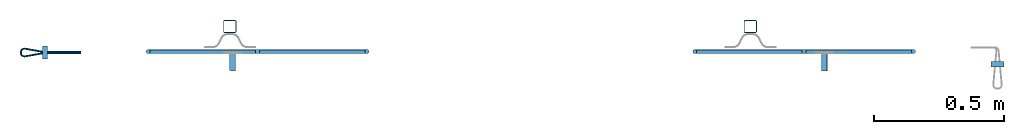
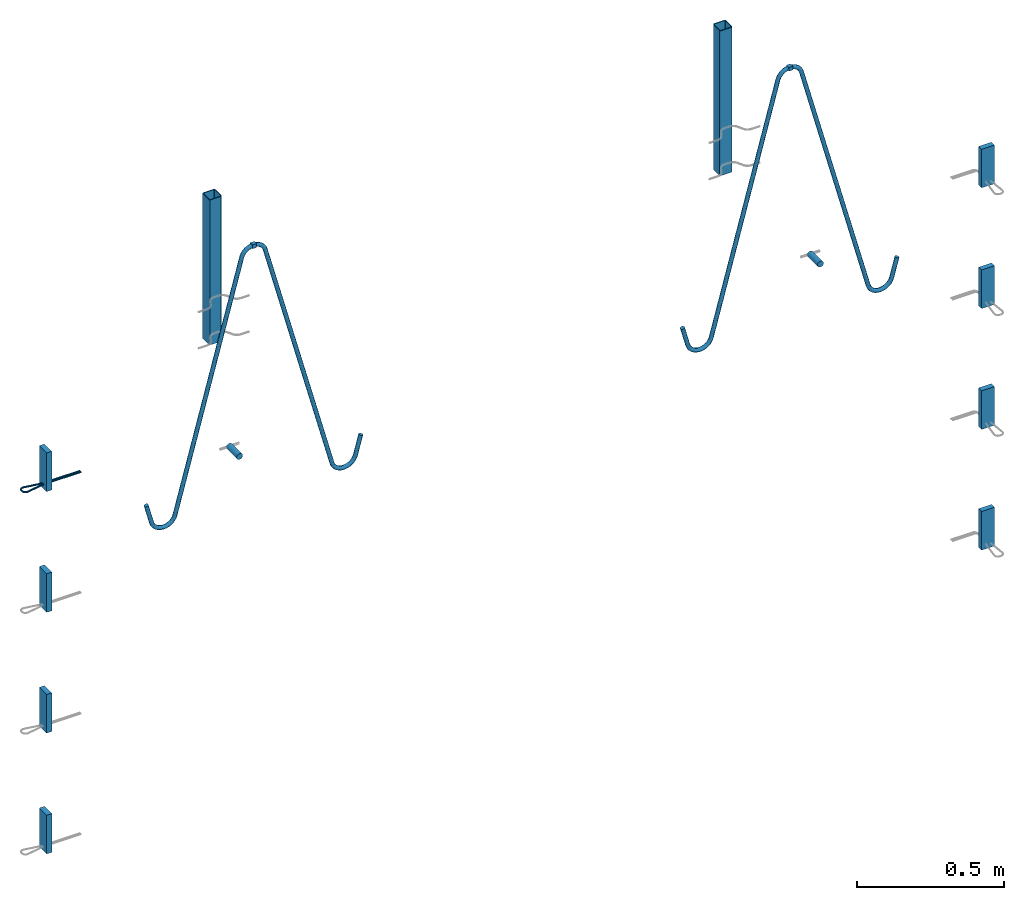
# One storey, part 1 of 5: 8 plates, 6 beams, 3 reinforcing bars, 14 elements without a shape of their own.
"""IFC2X3 building model written with IfcOpenShell, lengths in millimetres."""

from ifc_helpers import new_model, entity, si_unit, frame, origin_with_axes, origin_2d_with_axis, place, context, subcontext, project, spatial, polyline, rectangle, hollow_rectangle, circle, outline, extrude, source, transform, mapped, material, type_object, element, aggregate, save


model = new_model("IFC2X3")

# Units and contexts
model_context = context("Model", 3, precision=1e-05, world=origin_with_axes())
body_context = subcontext(model_context, "Body", "Model", "MODEL_VIEW")
ifc_project = project(units=[si_unit("LENGTHUNIT", "METRE", prefix="MILLI"), si_unit("AREAUNIT", "SQUARE_METRE"), si_unit("VOLUMEUNIT", "CUBIC_METRE"), si_unit("MASSUNIT", "GRAM", prefix="KILO"), si_unit("TIMEUNIT", "SECOND"), si_unit("PLANEANGLEUNIT", "RADIAN"), si_unit("SOLIDANGLEUNIT", "STERADIAN"), si_unit("THERMODYNAMICTEMPERATUREUNIT", "DEGREE_CELSIUS"), si_unit("LUMINOUSINTENSITYUNIT", "LUMEN")], contexts=[model_context])

# Site, building, storey
site_placement = place(None, origin_with_axes())
site = spatial("IfcSite", under=ifc_project, at=site_placement, CompositionType="ELEMENT")
building_placement = place(site_placement, origin_with_axes())
building = spatial("IfcBuilding", under=site, at=building_placement, Name="Undefined", CompositionType="ELEMENT")
storey_placement = place(building_placement, origin_with_axes())
storey = spatial("IfcBuildingStorey", under=building, at=storey_placement, Name="Undefined", CompositionType="ELEMENT", Elevation=0.0)

# Assembly, beam
assembly_1_placement = place(storey_placement, origin_with_axes())
assembly_1 = element("IfcElementAssembly", 1, at=assembly_1_placement, inside=storey, Name="Steel Assembly", AssemblyPlace="NOTDEFINED", PredefinedType="RIGID_FRAME")
ifc_material_1 = material(Name="STEEL/S235JR")
beam_type_1 = type_object("IfcBeamType", Name="16X16", PredefinedType="NOTDEFINED")
beam_1_placement = place(assembly_1_placement, frame((44434.4290182068, 6578.52776284339, 2796.99992149588), z_axis=(0.0, 0.0, 1.0), x_axis=(-0.999999999544916, 3.01690000137701e-05, 0.0)))
beam_1 = element("IfcBeam", 2, at=beam_1_placement, type_object=beam_type_1, material=ifc_material_1, Name="SA_16", ObjectType="16X16", context=body_context, shape_type="SweptSolid", body=[
    extrude(rectangle(XDim=16.0, YDim=16.0, at=origin_2d_with_axis()), frame((15.9999999994088, 0.0, -4.54747350886464e-13), z_axis=(-1.0, 0.0, 0.0), x_axis=(0.0, -1.0, 0.0)), (0.0, 0.0, 1.0), 16.0),
])

assembly_2_placement = place(storey_placement, origin_with_axes())
assembly_2 = element("IfcElementAssembly", 3, at=assembly_2_placement, inside=storey, Name="Steel Assembly", AssemblyPlace="NOTDEFINED", PredefinedType="RIGID_FRAME")
beam_2_placement = place(assembly_2_placement, frame((42318.4290192326, 6578.59160042399, 2796.99992149588), z_axis=(0.0, 0.0, 1.0), x_axis=(0.999999999544916, -3.01690000137153e-05, 0.0)))
beam_2 = element("IfcBeam", 4, at=beam_2_placement, type_object=beam_type_1, material=ifc_material_1, Name="SA_16", ObjectType="16X16", context=body_context, shape_type="SweptSolid", body=[
    extrude(rectangle(XDim=16.0, YDim=16.0, at=origin_2d_with_axis()), frame((15.9999999994088, 0.0, -4.54747350886464e-13), z_axis=(-1.0, 0.0, 0.0), x_axis=(0.0, -1.0, 0.0)), (0.0, 0.0, 1.0), 16.0),
])

assembly_3_placement = place(storey_placement, origin_with_axes())
assembly_3 = element("IfcElementAssembly", 5, at=assembly_3_placement, inside=storey, Name="Steel Assembly", AssemblyPlace="NOTDEFINED", PredefinedType="RIGID_FRAME")
ifc_material_2 = material(Name="STEEL/S235J0")
beam_type_2 = type_object("IfcBeamType", Name="P50X50X3", PredefinedType="NOTDEFINED")
beam_3_placement = place(assembly_3_placement, frame((44220.0052770704, 6674.91736716637, 2984.99992149547), z_axis=(0.999999999544916, -3.01690000137153e-05, 0.0), x_axis=(-1.34689347184514e-12, 3.00310696000483e-13, -1.0)))
beam_3 = element("IfcBeam", 6, at=beam_3_placement, type_object=beam_type_2, material=ifc_material_2, Name="603", ObjectType="P50X50X3", context=body_context, shape_type="SweptSolid", body=[
    extrude(hollow_rectangle(XDim=50.0, YDim=50.0, WallThickness=3.0, InnerFilletRadius=3.0, OuterFilletRadius=6.0, at=origin_2d_with_axis()), frame((600.0, 9.09494701772928e-13, 0.0), z_axis=(-1.0, 0.0, 0.0), x_axis=(0.0, -1.0, 0.0)), (0.0, 0.0, 1.0), 600.0),
])
aggregate(assembly_3, [beam_3])

assembly_4_placement = place(storey_placement, origin_with_axes())
assembly_4 = element("IfcElementAssembly", 7, at=assembly_4_placement, inside=storey, Name="Steel Assembly", AssemblyPlace="NOTDEFINED", PredefinedType="RIGID_FRAME")
beam_4_placement = place(assembly_4_placement, frame((42220.0052789568, 6674.97770520946, 2984.99992151013), z_axis=(0.999999999544916, -3.01690000137153e-05, 0.0), x_axis=(-1.34689347184514e-12, 3.00310696000483e-13, -1.0)))
beam_4 = element("IfcBeam", 8, at=beam_4_placement, type_object=beam_type_2, material=ifc_material_2, Name="603", ObjectType="P50X50X3", context=body_context, shape_type="SweptSolid", body=[
    extrude(hollow_rectangle(XDim=50.0, YDim=50.0, WallThickness=3.0, InnerFilletRadius=3.0, OuterFilletRadius=6.0, at=origin_2d_with_axis()), frame((600.0, 9.09494701772928e-13, 0.0), z_axis=(-1.0, 0.0, 0.0), x_axis=(0.0, -1.0, 0.0)), (0.0, 0.0, 1.0), 600.0),
])
aggregate(assembly_4, [beam_4])

assembly_5_placement = place(storey_placement, origin_with_axes())
assembly_5 = element("IfcElementAssembly", 9, at=assembly_5_placement, inside=storey, Name="Steel Assembly", AssemblyPlace="NOTDEFINED", PredefinedType="RIGID_FRAME")
ifc_material_3 = material()
beam_type_3 = type_object("IfcBeamType", Name="D24", PredefinedType="NOTDEFINED")
beam_5_placement = place(assembly_5_placement, frame((44504.4034584691, 6504.90878689932, 1999.99992148783), z_axis=(0.0, 0.0, 1.0), x_axis=(3.01689999883942e-05, 0.999999999544916, 0.0)))
beam_5 = element("IfcBeam", 10, at=beam_5_placement, type_object=beam_type_3, material=ifc_material_3, ObjectType="D24", context=body_context, shape_type="SweptSolid", body=[
    extrude(circle(Radius=12.0, at=origin_2d_with_axis()), frame((70.000000000261, 0.0, 2.27373675443232e-13), z_axis=(-1.0, 0.0, 0.0), x_axis=(0.0, -1.0, 0.0)), (0.0, 0.0, 1.0), 70.0),
])
aggregate(assembly_5, [beam_5])

assembly_6_placement = place(storey_placement, origin_with_axes())
assembly_6 = element("IfcElementAssembly", 11, at=assembly_6_placement, inside=storey, Name="Steel Assembly", AssemblyPlace="NOTDEFINED", PredefinedType="RIGID_FRAME")
beam_6_placement = place(assembly_6_placement, frame((42230.0001505156, 6504.97740344453, 1999.99992150867), z_axis=(0.0, 0.0, 1.0), x_axis=(3.01689999883942e-05, 0.999999999544916, 0.0)))
beam_6 = element("IfcBeam", 12, at=beam_6_placement, type_object=beam_type_3, material=ifc_material_3, ObjectType="D24", context=body_context, shape_type="SweptSolid", body=[
    extrude(circle(Radius=12.0, at=origin_2d_with_axis()), frame((70.000000000261, 0.0, 2.27373675443232e-13), z_axis=(-1.0, 0.0, 0.0), x_axis=(0.0, -1.0, 0.0)), (0.0, 0.0, 1.0), 70.0),
])
aggregate(assembly_6, [beam_6])

# Assembly, plate
assembly_7_placement = place(storey_placement, origin_with_axes())
assembly_7 = element("IfcElementAssembly", 13, at=assembly_7_placement, inside=storey, Name="Steel Assembly", AssemblyPlace="NOTDEFINED", PredefinedType="RIGID_FRAME")
ifc_material_4 = material(Name="STEEL/Steel_Undefined")
plate_type = type_object("IfcPlateType", Name="PL160X20", PredefinedType="NOTDEFINED")
plate_1_placement = place(assembly_7_placement, frame((45194.4018553906, 6519.89476329164, 2162.4999215154), z_axis=(-1.34689347184514e-12, 3.00310696000483e-13, -1.0), x_axis=(-0.999999999544916, 3.01690000137701e-05, 0.0)))
plate_1 = element("IfcPlate", 14, at=plate_1_placement, type_object=plate_type, material=ifc_material_4, Name="PVL80", ObjectType="PL160X20", context=body_context, shape_type="SweptSolid", body=[
    extrude(outline(polyline([(0.0, 0.0), (49.9999999994689, -5.50244294572622e-10), (49.9999999993233, 19.9999999995835), (4.8748916015029e-10, 20.0000000000382), (0.0, 0.0)])), frame((0.0, 0.0, -80.0), z_axis=(0.0, 0.0, 1.0), x_axis=(1.0, 0.0, 0.0)), (0.0, 0.0, 1.0), 160.0),
])
aggregate(assembly_7, [plate_1])

assembly_8_placement = place(storey_placement, origin_with_axes())
assembly_8 = element("IfcElementAssembly", 15, at=assembly_8_placement, inside=storey, Name="Steel Assembly", AssemblyPlace="NOTDEFINED", PredefinedType="RIGID_FRAME")
plate_2_placement = place(assembly_8_placement, frame((45194.4018553915, 6519.89476329164, 1662.4999215154), z_axis=(-1.34689347184514e-12, 3.00310696000483e-13, -1.0), x_axis=(-0.999999999544916, 3.01690000137701e-05, 0.0)))
plate_2 = element("IfcPlate", 16, at=plate_2_placement, type_object=plate_type, material=ifc_material_4, Name="PVL80", ObjectType="PL160X20", context=body_context, shape_type="SweptSolid", body=[
    extrude(outline(polyline([(0.0, 0.0), (49.9999999994689, -5.50244294572622e-10), (49.9999999993233, 19.9999999995835), (4.8748916015029e-10, 20.0000000000382), (0.0, 0.0)])), frame((0.0, 0.0, -80.0), z_axis=(0.0, 0.0, 1.0), x_axis=(1.0, 0.0, 0.0)), (0.0, 0.0, 1.0), 160.0),
])
aggregate(assembly_8, [plate_2])

assembly_9_placement = place(storey_placement, origin_with_axes())
assembly_9 = element("IfcElementAssembly", 17, at=assembly_9_placement, inside=storey, Name="Steel Assembly", AssemblyPlace="NOTDEFINED", PredefinedType="RIGID_FRAME")
plate_3_placement = place(assembly_9_placement, frame((45194.4018553924, 6519.89476329164, 1162.4999215154), z_axis=(-1.34689347184514e-12, 3.00310696000483e-13, -1.0), x_axis=(-0.999999999544916, 3.01690000137701e-05, 0.0)))
plate_3 = element("IfcPlate", 18, at=plate_3_placement, type_object=plate_type, material=ifc_material_4, Name="PVL80", ObjectType="PL160X20", context=body_context, shape_type="SweptSolid", body=[
    extrude(outline(polyline([(0.0, 0.0), (49.9999999994689, -5.50244294572622e-10), (49.9999999993233, 19.9999999995835), (4.8748916015029e-10, 20.0000000000382), (0.0, 0.0)])), frame((0.0, 0.0, -80.0), z_axis=(0.0, 0.0, 1.0), x_axis=(1.0, 0.0, 0.0)), (0.0, 0.0, 1.0), 160.0),
])
aggregate(assembly_9, [plate_3])

assembly_10_placement = place(storey_placement, origin_with_axes())
assembly_10 = element("IfcElementAssembly", 19, at=assembly_10_placement, inside=storey, Name="Steel Assembly", AssemblyPlace="NOTDEFINED", PredefinedType="RIGID_FRAME")
plate_4_placement = place(assembly_10_placement, frame((45194.4018553933, 6519.89476329164, 662.4999215154), z_axis=(-1.34689347184514e-12, 3.00310696000483e-13, -1.0), x_axis=(-0.999999999544916, 3.01690000137701e-05, 0.0)))
plate_4 = element("IfcPlate", 20, at=plate_4_placement, type_object=plate_type, material=ifc_material_4, Name="PVL80", ObjectType="PL160X20", context=body_context, shape_type="SweptSolid", body=[
    extrude(outline(polyline([(0.0, 0.0), (49.9999999994689, -5.50244294572622e-10), (49.9999999993233, 19.9999999995835), (4.8748916015029e-10, 20.0000000000382), (0.0, 0.0)])), frame((0.0, 0.0, -80.0), z_axis=(0.0, 0.0, 1.0), x_axis=(1.0, 0.0, 0.0)), (0.0, 0.0, 1.0), 160.0),
])
aggregate(assembly_10, [plate_4])

assembly_11_placement = place(storey_placement, origin_with_axes())
assembly_11 = element("IfcElementAssembly", 21, at=assembly_11_placement, inside=storey, Name="Steel Assembly", AssemblyPlace="NOTDEFINED", PredefinedType="RIGID_FRAME")
plate_5_placement = place(assembly_11_placement, frame((41500.0015084842, 6549.99942681677, 2162.49992151551), z_axis=(-1.34689347184514e-12, 3.00310696000483e-13, -1.0), x_axis=(3.01689999883942e-05, 0.999999999544916, 0.0)))
plate_5 = element("IfcPlate", 22, at=plate_5_placement, type_object=plate_type, material=ifc_material_4, Name="PVL80", ObjectType="PL160X20", context=body_context, shape_type="SweptSolid", body=[
    extrude(outline(polyline([(0.0, 0.0), (49.9999999994689, -5.50244294572622e-10), (49.9999999993233, 19.9999999995835), (4.8748916015029e-10, 20.0000000000382), (0.0, 0.0)])), frame((0.0, 0.0, -80.0), z_axis=(0.0, 0.0, 1.0), x_axis=(1.0, 0.0, 0.0)), (0.0, 0.0, 1.0), 160.0),
])

assembly_12_placement = place(storey_placement, origin_with_axes())
assembly_12 = element("IfcElementAssembly", 23, at=assembly_12_placement, inside=storey, Name="Steel Assembly", AssemblyPlace="NOTDEFINED", PredefinedType="RIGID_FRAME")
plate_6_placement = place(assembly_12_placement, frame((41500.0015084851, 6549.99942681677, 1662.49992151551), z_axis=(-1.34689347184514e-12, 3.00310696000483e-13, -1.0), x_axis=(3.01689999883942e-05, 0.999999999544916, 0.0)))
plate_6 = element("IfcPlate", 24, at=plate_6_placement, type_object=plate_type, material=ifc_material_4, Name="PVL80", ObjectType="PL160X20", context=body_context, shape_type="SweptSolid", body=[
    extrude(outline(polyline([(0.0, 0.0), (49.9999999994689, -5.50244294572622e-10), (49.9999999993233, 19.9999999995835), (4.8748916015029e-10, 20.0000000000382), (0.0, 0.0)])), frame((0.0, 0.0, -80.0), z_axis=(0.0, 0.0, 1.0), x_axis=(1.0, 0.0, 0.0)), (0.0, 0.0, 1.0), 160.0),
])
aggregate(assembly_12, [plate_6])

assembly_13_placement = place(storey_placement, origin_with_axes())
assembly_13 = element("IfcElementAssembly", 25, at=assembly_13_placement, inside=storey, Name="Steel Assembly", AssemblyPlace="NOTDEFINED", PredefinedType="RIGID_FRAME")
plate_7_placement = place(assembly_13_placement, frame((41500.001508486, 6549.99942681677, 1162.49992151551), z_axis=(-1.34689347184514e-12, 3.00310696000483e-13, -1.0), x_axis=(3.01689999883942e-05, 0.999999999544916, 0.0)))
plate_7 = element("IfcPlate", 26, at=plate_7_placement, type_object=plate_type, material=ifc_material_4, Name="PVL80", ObjectType="PL160X20", context=body_context, shape_type="SweptSolid", body=[
    extrude(outline(polyline([(0.0, 0.0), (49.9999999994689, -5.50244294572622e-10), (49.9999999993233, 19.9999999995835), (4.8748916015029e-10, 20.0000000000382), (0.0, 0.0)])), frame((0.0, 0.0, -80.0), z_axis=(0.0, 0.0, 1.0), x_axis=(1.0, 0.0, 0.0)), (0.0, 0.0, 1.0), 160.0),
])
aggregate(assembly_13, [plate_7])

assembly_14_placement = place(storey_placement, origin_with_axes())
assembly_14 = element("IfcElementAssembly", 27, at=assembly_14_placement, inside=storey, Name="Steel Assembly", AssemblyPlace="NOTDEFINED", PredefinedType="RIGID_FRAME")
plate_8_placement = place(assembly_14_placement, frame((41500.001508487, 6549.99942681677, 662.499921515511), z_axis=(-1.34689347184514e-12, 3.00310696000483e-13, -1.0), x_axis=(3.01689999883942e-05, 0.999999999544916, 0.0)))
plate_8 = element("IfcPlate", 28, at=plate_8_placement, type_object=plate_type, material=ifc_material_4, Name="PVL80", ObjectType="PL160X20", context=body_context, shape_type="SweptSolid", body=[
    extrude(outline(polyline([(0.0, 0.0), (49.9999999994689, -5.50244294572622e-10), (49.9999999993233, 19.9999999995835), (4.8748916015029e-10, 20.0000000000382), (0.0, 0.0)])), frame((0.0, 0.0, -80.0), z_axis=(0.0, 0.0, 1.0), x_axis=(1.0, 0.0, 0.0)), (0.0, 0.0, 1.0), 160.0),
])
aggregate(assembly_14, [plate_8])

# Reinforcing bar
ifc_material_5 = material(Name="S235JR")
ifc_direction_1 = entity("IfcDirection", [-0.866025403785718, 3.20860608224154e-13, -0.499999999997785])
vector_1 = entity("IfcVector", ifc_direction_1, 1.0)
ifc_direction_2 = entity("IfcDirection", [0.0, -1.0, 0.0])
ifc_direction_3 = entity("IfcDirection", [-0.499999999997785, -1.6151996382252e-13, 0.866025403785717])
vector_2 = entity("IfcVector", entity("IfcDirection", [1.0, 0.0, 0.0]), 1.0)
ifc_direction_4 = entity("IfcDirection", [0.0, 1.0, 0.0])
shared_shape_1 = source(origin_with_axes(), body_context, "Body", "AdvancedSweptSolid", [
    entity("IfcSweptDiskSolid", entity("IfcCompositeCurve", [entity("IfcCompositeCurveSegment", "CONTINUOUS", True, entity("IfcTrimmedCurve", entity("IfcLine", entity("IfcCartesianPoint", [0.0, 0.0, 0.0]), vector_1), [entity("IfcParameterValue", 0.0)], [entity("IfcParameterValue", 81.1547005382548)], True, "PARAMETER")), entity("IfcCompositeCurveSegment", "CONTINUOUS", True, entity("IfcTrimmedCurve", entity("IfcCircle", entity("IfcAxis2Placement3D", entity("IfcCartesianPoint", [-47.282032302853, 3.34692649107894e-11, -80.4145188430906]), ifc_direction_2, ifc_direction_3), 46.0), [entity("IfcParameterValue", 0.0)], [entity("IfcParameterValue", 1.04719755119781)], True, "PARAMETER")), entity("IfcCompositeCurveSegment", "CONTINUOUS", True, entity("IfcTrimmedCurve", entity("IfcLine", entity("IfcCartesianPoint", [-93.282032302853, 4.2536483881497e-11, -80.4145188430287]), entity("IfcVector", entity("IfcDirection", [-1.34689347184514e-12, 3.00310696000483e-13, -1.0]), 1.0)), [entity("IfcParameterValue", 0.0)], [entity("IfcParameterValue", 3.15470053769324)], True, "PARAMETER")), entity("IfcCompositeCurveSegment", "CONTINUOUS", True, entity("IfcTrimmedCurve", entity("IfcCircle", entity("IfcAxis2Placement3D", entity("IfcCartesianPoint", [-47.2820323028572, 3.48200843641559e-11, -83.5692193807838]), ifc_direction_2, entity("IfcDirection", [-1.0, 0.0, 0.0])), 46.0), [entity("IfcParameterValue", 0.0)], [entity("IfcParameterValue", 1.57079632679689)], True, "PARAMETER")), entity("IfcCompositeCurveSegment", "CONTINUOUS", True, entity("IfcTrimmedCurve", entity("IfcLine", entity("IfcCartesianPoint", [-47.2820323028275, 4.86343763801609e-11, -129.569219380784]), vector_2), [entity("IfcParameterValue", 0.0)], [entity("IfcParameterValue", 1010.03909475912)], True, "PARAMETER")), entity("IfcCompositeCurveSegment", "CONTINUOUS", True, entity("IfcTrimmedCurve", entity("IfcCircle", entity("IfcAxis2Placement3D", entity("IfcCartesianPoint", [962.757062456323, -1.27518622041797e-10, -175.569219380131]), ifc_direction_4, entity("IfcDirection", [0.0, 0.0, 1.0])), 46.0), [entity("IfcParameterValue", 0.0)], [entity("IfcParameterValue", 1.30899693899997)], True, "PARAMETER")), entity("IfcCompositeCurveSegment", "CONTINUOUS", True, entity("IfcTrimmedCurve", entity("IfcLine", entity("IfcCartesianPoint", [1007.18965046566, -1.39531645496898e-10, -163.663543305574]), entity("IfcVector", entity("IfcDirection", [0.258819045099097, 2.46932619129869e-13, -0.965925826289986]), 1.0)), [entity("IfcParameterValue", 0.0)], [entity("IfcParameterValue", 3.06930795099772)], True, "PARAMETER")), entity("IfcCompositeCurveSegment", "CONTINUOUS", True, entity("IfcTrimmedCurve", entity("IfcCircle", entity("IfcAxis2Placement3D", entity("IfcCartesianPoint", [963.551457809315, -1.26736023788098e-10, -178.533943198836]), ifc_direction_4, entity("IfcDirection", [0.965925826289994, -2.61689336033564e-13, 0.258819045099065])), 46.0), [entity("IfcParameterValue", 0.0)], [entity("IfcParameterValue", 1.3089969390026)], True, "PARAMETER")), entity("IfcCompositeCurveSegment", "CONTINUOUS", True, entity("IfcTrimmedCurve", entity("IfcLine", entity("IfcCartesianPoint", [986.5514578089, -1.18879756923167e-10, -218.371111773161]), vector_1), [entity("IfcParameterValue", 0.0)], [entity("IfcParameterValue", 1010.03909475814)], True, "PARAMETER")), entity("IfcCompositeCurveSegment", "CONTINUOUS", True, entity("IfcTrimmedCurve", entity("IfcCircle", entity("IfcAxis2Placement3D", entity("IfcCartesianPoint", [134.831942927225, 2.08718813619157e-10, -763.227827717429]), ifc_direction_2, ifc_direction_3), 46.0), [entity("IfcParameterValue", 0.0)], [entity("IfcParameterValue", 1.57079632679948)], True, "PARAMETER")), entity("IfcCompositeCurveSegment", "CONTINUOUS", True, entity("IfcTrimmedCurve", entity("IfcLine", entity("IfcCartesianPoint", [94.994774353006, 2.23286247849186e-10, -786.227827717196]), entity("IfcVector", entity("IfcDirection", [0.499999999994933, 1.68173989760147e-13, -0.866025403787364]), 1.0)), [entity("IfcParameterValue", 0.0)], [entity("IfcParameterValue", 3.15470053771008)], True, "PARAMETER")), entity("IfcCompositeCurveSegment", "CONTINUOUS", True, entity("IfcTrimmedCurve", entity("IfcCircle", entity("IfcAxis2Placement3D", entity("IfcCartesianPoint", [136.409293196064, 2.08137965741503e-10, -765.959878524428]), ifc_direction_2, ifc_direction_1), 46.0), [entity("IfcParameterValue", 0.0)], [entity("IfcParameterValue", 1.04719755119516)], True, "PARAMETER")), entity("IfcCompositeCurveSegment", "DISCONTINUOUS", True, entity("IfcTrimmedCurve", entity("IfcLine", entity("IfcCartesianPoint", [136.409293195728, 2.22676951663172e-10, -811.959878524428]), vector_2), [entity("IfcParameterValue", 0.0)], [entity("IfcParameterValue", 81.1547005384137)], True, "PARAMETER"))], False), 8.0, None, 0.0, 2199.62028125433),
])
reinforcing_bar_1_placement = place(assembly_1_placement, frame((44107.1387462854, 6578.53763686415, 1742.85016237043), z_axis=(-0.965925825826314, 2.91409999945245e-05, 0.258819045189018), x_axis=(0.258819045071243, -7.80800000212314e-06, 0.965925826265891)))
reinforcing_bar_1 = element("IfcReinforcingBar", 29, at=reinforcing_bar_1_placement, material=ifc_material_5, Name="SA_16", BarRole="NOTDEFINED", CrossSectionArea=0.0, NominalDiameter=16.0, context=body_context, shape_type="MappedRepresentation", body=[
    mapped(shared_shape_1, transform((93.2820323029191, -5.63886715099216e-11, 129.569219380814))),
])

aggregate(assembly_1, [beam_1, reinforcing_bar_1])

ifc_direction_5 = entity("IfcDirection", [-0.866025403785718, 3.20860608224154e-13, -0.499999999997785])
ifc_direction_6 = entity("IfcDirection", [0.0, -1.0, 0.0])
ifc_direction_7 = entity("IfcDirection", [-0.499999999997785, -1.6151996382252e-13, 0.866025403785717])
ifc_direction_8 = entity("IfcDirection", [1.0, 0.0, 0.0])
ifc_direction_9 = entity("IfcDirection", [0.0, 1.0, 0.0])
shared_shape_2 = source(origin_with_axes(), body_context, "Body", "AdvancedSweptSolid", [
    entity("IfcSweptDiskSolid", entity("IfcCompositeCurve", [entity("IfcCompositeCurveSegment", "CONTINUOUS", True, entity("IfcTrimmedCurve", entity("IfcLine", entity("IfcCartesianPoint", [0.0, 0.0, 0.0]), entity("IfcVector", ifc_direction_5, 1.0)), [entity("IfcParameterValue", 0.0)], [entity("IfcParameterValue", 81.1547005382589)], True, "PARAMETER")), entity("IfcCompositeCurveSegment", "CONTINUOUS", True, entity("IfcTrimmedCurve", entity("IfcCircle", entity("IfcAxis2Placement3D", entity("IfcCartesianPoint", [-47.282032302853, 3.34692649107894e-11, -80.4145188430906]), ifc_direction_6, ifc_direction_7), 46.0), [entity("IfcParameterValue", 0.0)], [entity("IfcParameterValue", 1.04719755119774)], True, "PARAMETER")), entity("IfcCompositeCurveSegment", "CONTINUOUS", True, entity("IfcTrimmedCurve", entity("IfcLine", entity("IfcCartesianPoint", [-93.282032302853, 4.2536483881497e-11, -80.4145188430287]), entity("IfcVector", entity("IfcDirection", [-1.34689347184514e-12, 3.00310696000483e-13, -1.0]), 1.0)), [entity("IfcParameterValue", 0.0)], [entity("IfcParameterValue", 3.15470053770284)], True, "PARAMETER")), entity("IfcCompositeCurveSegment", "CONTINUOUS", True, entity("IfcTrimmedCurve", entity("IfcCircle", entity("IfcAxis2Placement3D", entity("IfcCartesianPoint", [-47.2820323028572, 3.48200843641559e-11, -83.5692193807838]), ifc_direction_6, entity("IfcDirection", [-1.0, 0.0, 0.0])), 46.0), [entity("IfcParameterValue", 0.0)], [entity("IfcParameterValue", 1.57079632679688)], True, "PARAMETER")), entity("IfcCompositeCurveSegment", "CONTINUOUS", True, entity("IfcTrimmedCurve", entity("IfcLine", entity("IfcCartesianPoint", [-47.2820323028275, 4.86343763801609e-11, -129.569219380784]), entity("IfcVector", ifc_direction_8, 1.0)), [entity("IfcParameterValue", 0.0)], [entity("IfcParameterValue", 1010.03909475912)], True, "PARAMETER")), entity("IfcCompositeCurveSegment", "CONTINUOUS", True, entity("IfcTrimmedCurve", entity("IfcCircle", entity("IfcAxis2Placement3D", entity("IfcCartesianPoint", [962.757062456323, -1.27518622041797e-10, -175.569219380131]), ifc_direction_9, entity("IfcDirection", [0.0, 0.0, 1.0])), 46.0), [entity("IfcParameterValue", 0.0)], [entity("IfcParameterValue", 1.30899693899996)], True, "PARAMETER")), entity("IfcCompositeCurveSegment", "CONTINUOUS", True, entity("IfcTrimmedCurve", entity("IfcLine", entity("IfcCartesianPoint", [1007.18965046566, -1.39531645496898e-10, -163.663543305574]), entity("IfcVector", entity("IfcDirection", [0.258819045099097, 2.46932619129869e-13, -0.965925826289986]), 1.0)), [entity("IfcParameterValue", 0.0)], [entity("IfcParameterValue", 3.06930795098277)], True, "PARAMETER")), entity("IfcCompositeCurveSegment", "CONTINUOUS", True, entity("IfcTrimmedCurve", entity("IfcCircle", entity("IfcAxis2Placement3D", entity("IfcCartesianPoint", [963.551457809315, -1.26736023788098e-10, -178.533943198836]), ifc_direction_9, entity("IfcDirection", [0.965925826289994, -2.61689336033564e-13, 0.258819045099065])), 46.0), [entity("IfcParameterValue", 0.0)], [entity("IfcParameterValue", 1.30899693900261)], True, "PARAMETER")), entity("IfcCompositeCurveSegment", "CONTINUOUS", True, entity("IfcTrimmedCurve", entity("IfcLine", entity("IfcCartesianPoint", [986.5514578089, -1.18879756923167e-10, -218.371111773161]), entity("IfcVector", ifc_direction_5, 1.0)), [entity("IfcParameterValue", 0.0)], [entity("IfcParameterValue", 1010.03909475814)], True, "PARAMETER")), entity("IfcCompositeCurveSegment", "CONTINUOUS", True, entity("IfcTrimmedCurve", entity("IfcCircle", entity("IfcAxis2Placement3D", entity("IfcCartesianPoint", [134.831942927225, 2.08718813619157e-10, -763.227827717429]), ifc_direction_6, ifc_direction_7), 46.0), [entity("IfcParameterValue", 0.0)], [entity("IfcParameterValue", 1.57079632679935)], True, "PARAMETER")), entity("IfcCompositeCurveSegment", "CONTINUOUS", True, entity("IfcTrimmedCurve", entity("IfcLine", entity("IfcCartesianPoint", [94.994774353006, 2.23286247849186e-10, -786.227827717196]), entity("IfcVector", entity("IfcDirection", [0.499999999994933, 1.68173989760147e-13, -0.866025403787364]), 1.0)), [entity("IfcParameterValue", 0.0)], [entity("IfcParameterValue", 3.15470053771876)], True, "PARAMETER")), entity("IfcCompositeCurveSegment", "CONTINUOUS", True, entity("IfcTrimmedCurve", entity("IfcCircle", entity("IfcAxis2Placement3D", entity("IfcCartesianPoint", [136.409293196064, 2.08137965741503e-10, -765.959878524428]), ifc_direction_6, ifc_direction_5), 46.0), [entity("IfcParameterValue", 0.0)], [entity("IfcParameterValue", 1.04719755119515)], True, "PARAMETER")), entity("IfcCompositeCurveSegment", "DISCONTINUOUS", True, entity("IfcTrimmedCurve", entity("IfcLine", entity("IfcCartesianPoint", [136.409293195728, 2.22676951663172e-10, -811.959878524428]), entity("IfcVector", ifc_direction_8, 1.0)), [entity("IfcParameterValue", 0.0)], [entity("IfcParameterValue", 81.1547005384157)], True, "PARAMETER"))], False), 8.0, None, 0.0, 2199.62028125433),
])
reinforcing_bar_2_placement = place(assembly_2_placement, frame((42645.7192911539, 6578.58172640323, 1742.85016237043), z_axis=(0.965925825826314, -2.91409999945245e-05, 0.258819045189018), x_axis=(-0.258819045071243, 7.80800000212314e-06, 0.965925826265891)))
reinforcing_bar_2 = element("IfcReinforcingBar", 30, at=reinforcing_bar_2_placement, material=ifc_material_5, Name="SA_16", BarRole="NOTDEFINED", CrossSectionArea=0.0, NominalDiameter=16.0, context=body_context, shape_type="MappedRepresentation", body=[
    mapped(shared_shape_2, transform((93.2820323029191, -5.63886715099216e-11, 129.569219380814))),
])

aggregate(assembly_2, [beam_2, reinforcing_bar_2])

ifc_material_6 = material(Name="Undefined")
ifc_direction_10 = entity("IfcDirection", [-1.0, 0.0, 0.0])
ifc_direction_11 = entity("IfcDirection", [0.0, -1.0, 0.0])
ifc_direction_12 = entity("IfcDirection", [0.0, 0.0, 1.0])
ifc_direction_13 = entity("IfcDirection", [0.0, 1.0, 0.0])
shared_shape_3 = source(origin_with_axes(), body_context, "Body", "AdvancedSweptSolid", [
    entity("IfcSweptDiskSolid", entity("IfcCompositeCurve", [entity("IfcCompositeCurveSegment", "CONTINUOUS", True, entity("IfcTrimmedCurve", entity("IfcLine", entity("IfcCartesianPoint", [0.0, 0.0, 0.0]), entity("IfcVector", ifc_direction_10, 1.0)), [entity("IfcParameterValue", 0.0)], [entity("IfcParameterValue", 145.829645724688)], True, "PARAMETER")), entity("IfcCompositeCurveSegment", "CONTINUOUS", True, entity("IfcTrimmedCurve", entity("IfcCircle", entity("IfcAxis2Placement3D", entity("IfcCartesianPoint", [-145.829645724709, -2.65262580298724e-10, -13.4999999997726]), ifc_direction_11, ifc_direction_12), 13.5), [entity("IfcParameterValue", 0.0)], [entity("IfcParameterValue", 0.172953396990121)], True, "PARAMETER")), entity("IfcCompositeCurveSegment", "CONTINUOUS", True, entity("IfcTrimmedCurve", entity("IfcLine", entity("IfcCartesianPoint", [-148.152893530619, -2.69488543439533e-10, -0.201409110797394]), entity("IfcVector", entity("IfcDirection", [-0.985080806590758, -1.79185154884275e-12, -0.172092430067394]), 1.0)), [entity("IfcParameterValue", 0.0)], [entity("IfcParameterValue", 67.0237996918216)], True, "PARAMETER")), entity("IfcCompositeCurveSegment", "CONTINUOUS", True, entity("IfcTrimmedCurve", entity("IfcCircle", entity("IfcAxis2Placement3D", entity("IfcCartesianPoint", [-216.499999997725, -3.93811205867437e-10, 1.56289321686201]), ifc_direction_13, entity("IfcDirection", [0.172092430067394, 3.13034306724995e-13, -0.985080806590758])), 13.5), [entity("IfcParameterValue", 0.0)], [entity("IfcParameterValue", 1.74374972378283)], True, "PARAMETER")), entity("IfcCompositeCurveSegment", "CONTINUOUS", True, entity("IfcTrimmedCurve", entity("IfcLine", entity("IfcCartesianPoint", [-229.999999997725, -4.18367562815547e-10, 1.56289321685359]), entity("IfcVector", ifc_direction_12, 1.0)), [entity("IfcParameterValue", 0.0)], [entity("IfcParameterValue", 2.87421356694805)], True, "PARAMETER")), entity("IfcCompositeCurveSegment", "CONTINUOUS", True, entity("IfcTrimmedCurve", entity("IfcCircle", entity("IfcAxis2Placement3D", entity("IfcCartesianPoint", [-216.499999997727, -3.93811205867436e-10, 4.43710678381008]), ifc_direction_13, ifc_direction_10), 13.5), [entity("IfcParameterValue", 0.0)], [entity("IfcParameterValue", 1.74374972378711)], True, "PARAMETER")), entity("IfcCompositeCurveSegment", "CONTINUOUS", True, entity("IfcTrimmedCurve", entity("IfcLine", entity("IfcCartesianPoint", [-214.176752191777, -3.89585242726545e-10, 17.7356976727783]), entity("IfcVector", entity("IfcDirection", [0.985080806590238, 1.79185154884149e-12, -0.172092430070371]), 1.0)), [entity("IfcParameterValue", 0.0)], [entity("IfcParameterValue", 67.0237996918118)], True, "PARAMETER")), entity("IfcCompositeCurveSegment", "CONTINUOUS", True, entity("IfcTrimmedCurve", entity("IfcCircle", entity("IfcAxis2Placement3D", entity("IfcCartesianPoint", [-145.829645724675, -2.65262580298639e-10, 19.5000000002328]), ifc_direction_11, entity("IfcDirection", [-0.172092430070371, -3.13034306732766e-13, -0.985080806590238])), 13.5), [entity("IfcParameterValue", 0.0)], [entity("IfcParameterValue", 0.172953396990031)], True, "PARAMETER")), entity("IfcCompositeCurveSegment", "DISCONTINUOUS", True, entity("IfcTrimmedCurve", entity("IfcLine", entity("IfcCartesianPoint", [-145.829645724696, -2.65262580298694e-10, 6.00000000023283]), entity("IfcVector", entity("IfcDirection", [1.0, 0.0, 0.0]), 1.0)), [entity("IfcParameterValue", 0.0)], [entity("IfcParameterValue", 145.829645724703)], True, "PARAMETER"))], False), 3.5, None, 0.0, 432.414510641522),
])
reinforcing_bar_3_placement = place(assembly_11_placement, frame((41500.0023532172, 6577.99942680406, 2099.99992151551), z_axis=(3.01689999883942e-05, 0.999999999544916, 0.0), x_axis=(0.999999999544916, -3.01690000137153e-05, 0.0)))
reinforcing_bar_3 = element("IfcReinforcingBar", 31, at=reinforcing_bar_3_placement, material=ifc_material_6, Name="PVL80", BarRole="NOTDEFINED", CrossSectionArea=0.0, NominalDiameter=7.0, context=body_context, shape_type="MappedRepresentation", body=[
    mapped(shared_shape_3, transform((146.999999998545, 2.67391442321241e-10, -6.00000000023465))),
])

aggregate(assembly_11, [plate_5, reinforcing_bar_3])

save(model, "model.ifc")
